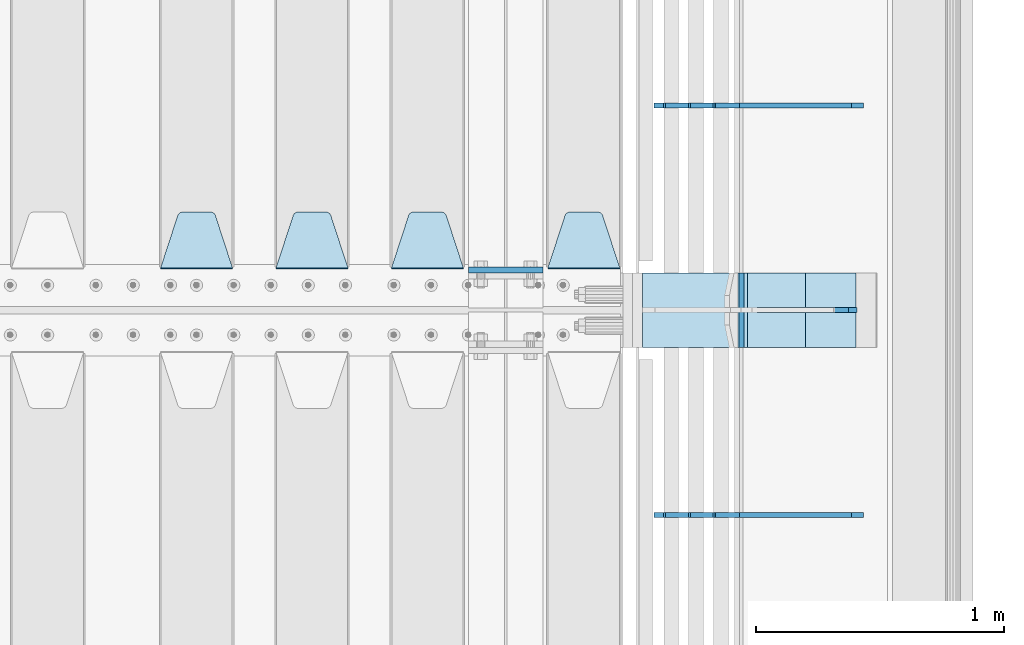
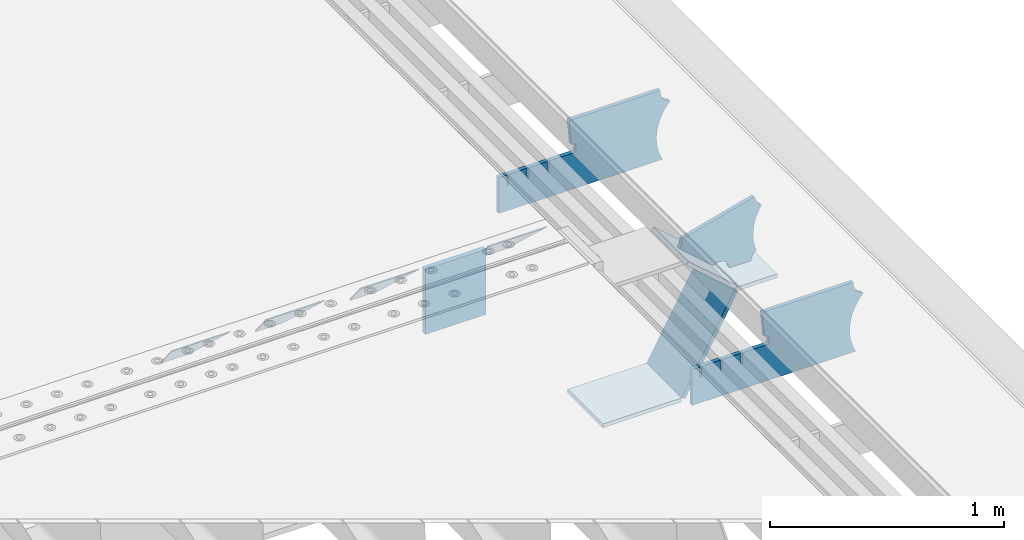
# One storey, part 226 of 247: 12 plates.
"""IFC2X3 building model written with IfcOpenShell, lengths in millimetres."""

from ifc_helpers import new_model, si_unit, frame, origin_with_axes, place, context, subcontext, project, spatial, faceted_brep, material, type_object, element, save


model = new_model("IFC2X3")

# Units and contexts
model_context = context("Model", 3, precision=1e-05, world=origin_with_axes())
body_context = subcontext(model_context, "Body", "Model", "MODEL_VIEW")
ifc_project = project(units=[si_unit("LENGTHUNIT", "METRE", prefix="MILLI"), si_unit("AREAUNIT", "SQUARE_METRE"), si_unit("VOLUMEUNIT", "CUBIC_METRE"), si_unit("MASSUNIT", "GRAM", prefix="KILO"), si_unit("TIMEUNIT", "SECOND"), si_unit("PLANEANGLEUNIT", "RADIAN"), si_unit("SOLIDANGLEUNIT", "STERADIAN"), si_unit("THERMODYNAMICTEMPERATUREUNIT", "DEGREE_CELSIUS"), si_unit("LUMINOUSINTENSITYUNIT", "LUMEN")], contexts=[model_context])

# Site, building, storey
site_placement = place(None, origin_with_axes())
site = spatial("IfcSite", under=ifc_project, at=site_placement, CompositionType="ELEMENT")
building_placement = place(site_placement, origin_with_axes())
building = spatial("IfcBuilding", under=site, at=building_placement, Name="Standard", CompositionType="ELEMENT")
storey_placement = place(building_placement, origin_with_axes())
storey = spatial("IfcBuildingStorey", under=building, at=storey_placement, Name="Undefined", CompositionType="ELEMENT", Elevation=0.0)

# Plates
ifc_material = material(Name="STEEL/S355N")
plate_type_1 = type_object("IfcPlateType", PredefinedType="NOTDEFINED")
plate_1_placement = place(storey_placement, frame((16195.0, 3162.5, -340.000000000044), z_axis=(0.0, 0.0, 1.0), x_axis=(1.0, 0.0, 0.0)))
element("IfcPlate", 1, at=plate_1_placement, inside=storey, type_object=plate_type_1, material=ifc_material, context=body_context, shape_type="Brep", body=[
    faceted_brep([(0.0, -12.5, 0.0), (0.0, -12.5, 340.0), (0.0, 12.5, 340.0), (0.0, 12.5, 0.0), (300.0, -12.5, 340.0), (300.0, 12.5, 340.0), (300.0, -12.5, 0.0), (300.0, 12.5, 0.0)], [[[0, 1, 2, 3]], [[1, 4, 5, 2]], [[4, 6, 7, 5]], [[6, 0, 3, 7]], [[5, 7, 3, 2]], [[6, 4, 1, 0]]]),
])
plate_type_2 = type_object("IfcPlateType", PredefinedType="NOTDEFINED")
plate_2_placement = place(storey_placement, frame((16805.0, 3168.23223304703, -1.76776695296758), z_axis=(0.0, 0.707106781186548, -0.707106781186547), x_axis=(-1.0, 0.0, 0.0)))
element("IfcPlate", 2, at=plate_2_placement, inside=storey, type_object=plate_type_2, material=ifc_material, context=body_context, shape_type="Brep", body=[
    faceted_brep([(0.0, -2.49999999999909, 0.0), (69.345504679477, -2.5, 300.17173142483), (69.345504679477, 2.50000000000091, 300.171731424831), (0.0, 2.5, -9.09494701772928e-13), (70.9274061199576, -2.5, 304.897442415399), (70.9274061199576, 2.50000000000091, 304.8974424154), (73.3818627772307, -2.49999999999909, 309.234538108527), (73.3818627772307, 2.5, 309.234538108526), (76.6187032999551, -2.5, 313.023683126102), (76.6187032999551, 2.50000000000091, 313.023683126102), (80.5190132704993, -2.49999999999909, 316.125672595371), (80.5190132704993, 2.50000000000091, 316.125672595372), (84.9395038596849, -2.49999999999909, 318.426546230476), (84.9395038596849, 2.5, 318.426546230475), (89.7177759439219, -2.5, 319.841774983274), (89.7177759439219, 2.50000000000091, 319.841774983275), (94.678286292652, -2.5, 320.319366455077), (94.678286292652, 2.50000000000091, 320.319366455077), (195.321713707348, -2.5, 320.319366455077), (195.321713707348, 2.50000000000091, 320.319366455077), (200.282224056078, -2.5, 319.841774983274), (200.282224056078, 2.50000000000091, 319.841774983275), (205.060496140315, -2.5, 318.426546230475), (205.060496140315, 2.5, 318.426546230474), (209.480986729501, -2.49999999999818, 316.12567259537), (209.480986729501, 2.50000000000091, 316.12567259537), (213.381296700045, -2.5, 313.023683126101), (213.381296700045, 2.50000000000091, 313.023683126101), (216.618137222769, -2.5, 309.234538108525), (216.618137222769, 2.5, 309.234538108525), (219.072593880042, -2.49999999999909, 304.897442415398), (219.072593880042, 2.5, 304.897442415398), (220.654495320523, -2.5, 300.17173142483), (220.654495320523, 2.50000000000091, 300.171731424831), (290.0, -2.49999999999909, 0.0), (290.0, 2.5, -9.09494701772928e-13)], [[[0, 1, 2, 3]], [[1, 4, 5, 2]], [[4, 6, 7, 5]], [[6, 8, 9, 7]], [[8, 10, 11, 9]], [[10, 12, 13, 11]], [[12, 14, 15, 13]], [[14, 16, 17, 15]], [[16, 18, 19, 17]], [[18, 20, 21, 19]], [[20, 22, 23, 21]], [[22, 24, 25, 23]], [[24, 26, 27, 25]], [[26, 28, 29, 27]], [[28, 30, 31, 29]], [[30, 32, 33, 31]], [[32, 34, 35, 33]], [[34, 0, 3, 35]], [[5, 7, 9, 11, 13, 15, 17, 19, 21, 23, 25, 27, 29, 31, 33, 35, 3, 2]], [[34, 32, 30, 28, 26, 24, 22, 20, 18, 16, 14, 12, 10, 8, 6, 4, 1, 0]]]),
])
plate_3_placement = place(storey_placement, frame((16175.0, 3168.23223304703, -1.76776695296758), z_axis=(0.0, 0.707106781186548, -0.707106781186547), x_axis=(-1.0, 0.0, 0.0)))
element("IfcPlate", 3, at=plate_3_placement, inside=storey, type_object=plate_type_2, material=ifc_material, context=body_context, shape_type="Brep", body=[
    faceted_brep([(0.0, -2.49999999999909, 0.0), (69.345504679477, -2.5, 300.17173142483), (69.345504679477, 2.50000000000091, 300.171731424831), (0.0, 2.5, -9.09494701772928e-13), (70.9274061199576, -2.5, 304.897442415399), (70.9274061199576, 2.50000000000091, 304.8974424154), (73.3818627772307, -2.49999999999909, 309.234538108527), (73.3818627772307, 2.5, 309.234538108526), (76.6187032999551, -2.5, 313.023683126102), (76.6187032999551, 2.50000000000091, 313.023683126102), (80.5190132704993, -2.49999999999909, 316.125672595371), (80.5190132704993, 2.50000000000091, 316.125672595372), (84.9395038596849, -2.49999999999909, 318.426546230476), (84.9395038596849, 2.5, 318.426546230475), (89.7177759439219, -2.5, 319.841774983274), (89.7177759439219, 2.50000000000091, 319.841774983275), (94.678286292652, -2.5, 320.319366455077), (94.678286292652, 2.50000000000091, 320.319366455077), (195.321713707348, -2.5, 320.319366455077), (195.321713707348, 2.50000000000091, 320.319366455077), (200.282224056078, -2.5, 319.841774983274), (200.282224056078, 2.50000000000091, 319.841774983275), (205.060496140315, -2.5, 318.426546230475), (205.060496140315, 2.5, 318.426546230474), (209.480986729501, -2.49999999999818, 316.12567259537), (209.480986729501, 2.50000000000091, 316.12567259537), (213.381296700045, -2.5, 313.023683126101), (213.381296700045, 2.50000000000091, 313.023683126101), (216.618137222769, -2.5, 309.234538108525), (216.618137222769, 2.5, 309.234538108525), (219.072593880042, -2.49999999999909, 304.897442415398), (219.072593880042, 2.5, 304.897442415398), (220.654495320523, -2.5, 300.17173142483), (220.654495320523, 2.50000000000091, 300.171731424831), (290.0, -2.49999999999909, 0.0), (290.0, 2.5, -9.09494701772928e-13)], [[[0, 1, 2, 3]], [[1, 4, 5, 2]], [[4, 6, 7, 5]], [[6, 8, 9, 7]], [[8, 10, 11, 9]], [[10, 12, 13, 11]], [[12, 14, 15, 13]], [[14, 16, 17, 15]], [[16, 18, 19, 17]], [[18, 20, 21, 19]], [[20, 22, 23, 21]], [[22, 24, 25, 23]], [[24, 26, 27, 25]], [[26, 28, 29, 27]], [[28, 30, 31, 29]], [[30, 32, 33, 31]], [[32, 34, 35, 33]], [[34, 0, 3, 35]], [[5, 7, 9, 11, 13, 15, 17, 19, 21, 23, 25, 27, 29, 31, 33, 35, 3, 2]], [[34, 32, 30, 28, 26, 24, 22, 20, 18, 16, 14, 12, 10, 8, 6, 4, 1, 0]]]),
])
plate_4_placement = place(storey_placement, frame((15710.0, 3168.23223304703, -1.76776695296758), z_axis=(0.0, 0.707106781186548, -0.707106781186547), x_axis=(-1.0, 0.0, 0.0)))
element("IfcPlate", 4, at=plate_4_placement, inside=storey, type_object=plate_type_2, material=ifc_material, context=body_context, shape_type="Brep", body=[
    faceted_brep([(0.0, -2.49999999999909, 0.0), (69.345504679477, -2.5, 300.17173142483), (69.345504679477, 2.50000000000091, 300.171731424831), (0.0, 2.5, -9.09494701772928e-13), (70.9274061199576, -2.5, 304.897442415399), (70.9274061199576, 2.50000000000091, 304.8974424154), (73.3818627772307, -2.49999999999909, 309.234538108527), (73.3818627772307, 2.5, 309.234538108526), (76.6187032999551, -2.5, 313.023683126102), (76.6187032999551, 2.50000000000091, 313.023683126102), (80.5190132704993, -2.49999999999909, 316.125672595371), (80.5190132704993, 2.50000000000091, 316.125672595372), (84.9395038596849, -2.49999999999909, 318.426546230476), (84.9395038596849, 2.5, 318.426546230475), (89.7177759439219, -2.5, 319.841774983274), (89.7177759439219, 2.50000000000091, 319.841774983275), (94.678286292652, -2.5, 320.319366455077), (94.678286292652, 2.50000000000091, 320.319366455077), (195.321713707348, -2.5, 320.319366455077), (195.321713707348, 2.50000000000091, 320.319366455077), (200.282224056078, -2.5, 319.841774983274), (200.282224056078, 2.50000000000091, 319.841774983275), (205.060496140315, -2.5, 318.426546230475), (205.060496140315, 2.5, 318.426546230474), (209.480986729501, -2.49999999999818, 316.12567259537), (209.480986729501, 2.50000000000091, 316.12567259537), (213.381296700045, -2.5, 313.023683126101), (213.381296700045, 2.50000000000091, 313.023683126101), (216.618137222769, -2.5, 309.234538108525), (216.618137222769, 2.5, 309.234538108525), (219.072593880042, -2.49999999999909, 304.897442415398), (219.072593880042, 2.5, 304.897442415398), (220.654495320523, -2.5, 300.17173142483), (220.654495320523, 2.50000000000091, 300.171731424831), (290.0, -2.49999999999909, 0.0), (290.0, 2.5, -9.09494701772928e-13)], [[[0, 1, 2, 3]], [[1, 4, 5, 2]], [[4, 6, 7, 5]], [[6, 8, 9, 7]], [[8, 10, 11, 9]], [[10, 12, 13, 11]], [[12, 14, 15, 13]], [[14, 16, 17, 15]], [[16, 18, 19, 17]], [[18, 20, 21, 19]], [[20, 22, 23, 21]], [[22, 24, 25, 23]], [[24, 26, 27, 25]], [[26, 28, 29, 27]], [[28, 30, 31, 29]], [[30, 32, 33, 31]], [[32, 34, 35, 33]], [[34, 0, 3, 35]], [[5, 7, 9, 11, 13, 15, 17, 19, 21, 23, 25, 27, 29, 31, 33, 35, 3, 2]], [[34, 32, 30, 28, 26, 24, 22, 20, 18, 16, 14, 12, 10, 8, 6, 4, 1, 0]]]),
])
plate_5_placement = place(storey_placement, frame((15245.0, 3168.23223304703, -1.76776695296758), z_axis=(0.0, 0.707106781186548, -0.707106781186547), x_axis=(-1.0, 0.0, 0.0)))
element("IfcPlate", 5, at=plate_5_placement, inside=storey, type_object=plate_type_2, material=ifc_material, context=body_context, shape_type="Brep", body=[
    faceted_brep([(0.0, -2.49999999999909, 0.0), (69.345504679477, -2.5, 300.17173142483), (69.345504679477, 2.50000000000091, 300.171731424831), (0.0, 2.5, -9.09494701772928e-13), (70.9274061199576, -2.5, 304.897442415399), (70.9274061199576, 2.50000000000091, 304.8974424154), (73.3818627772307, -2.49999999999909, 309.234538108527), (73.3818627772307, 2.5, 309.234538108526), (76.6187032999551, -2.5, 313.023683126102), (76.6187032999551, 2.50000000000091, 313.023683126102), (80.5190132704993, -2.49999999999909, 316.125672595371), (80.5190132704993, 2.50000000000091, 316.125672595372), (84.9395038596849, -2.49999999999909, 318.426546230476), (84.9395038596849, 2.5, 318.426546230475), (89.7177759439219, -2.5, 319.841774983274), (89.7177759439219, 2.50000000000091, 319.841774983275), (94.678286292652, -2.5, 320.319366455077), (94.678286292652, 2.50000000000091, 320.319366455077), (195.321713707348, -2.5, 320.319366455077), (195.321713707348, 2.50000000000091, 320.319366455077), (200.282224056078, -2.5, 319.841774983274), (200.282224056078, 2.50000000000091, 319.841774983275), (205.060496140315, -2.5, 318.426546230475), (205.060496140315, 2.5, 318.426546230474), (209.480986729501, -2.49999999999818, 316.12567259537), (209.480986729501, 2.50000000000091, 316.12567259537), (213.381296700045, -2.5, 313.023683126101), (213.381296700045, 2.50000000000091, 313.023683126101), (216.618137222769, -2.5, 309.234538108525), (216.618137222769, 2.5, 309.234538108525), (219.072593880042, -2.49999999999909, 304.897442415398), (219.072593880042, 2.5, 304.897442415398), (220.654495320523, -2.5, 300.17173142483), (220.654495320523, 2.50000000000091, 300.171731424831), (290.0, -2.49999999999909, 0.0), (290.0, 2.5, -9.09494701772928e-13)], [[[0, 1, 2, 3]], [[1, 4, 5, 2]], [[4, 6, 7, 5]], [[6, 8, 9, 7]], [[8, 10, 11, 9]], [[10, 12, 13, 11]], [[12, 14, 15, 13]], [[14, 16, 17, 15]], [[16, 18, 19, 17]], [[18, 20, 21, 19]], [[20, 22, 23, 21]], [[22, 24, 25, 23]], [[24, 26, 27, 25]], [[26, 28, 29, 27]], [[28, 30, 31, 29]], [[30, 32, 33, 31]], [[32, 34, 35, 33]], [[34, 0, 3, 35]], [[5, 7, 9, 11, 13, 15, 17, 19, 21, 23, 25, 27, 29, 31, 33, 35, 3, 2]], [[34, 32, 30, 28, 26, 24, 22, 20, 18, 16, 14, 12, 10, 8, 6, 4, 1, 0]]]),
])
plate_type_3 = type_object("IfcPlateType", PredefinedType="NOTDEFINED")
plate_6_placement = place(storey_placement, frame((17840.9988502513, 2999.99999999933, -28.9999913318487), z_axis=(0.260769276985653, 0.0, -0.965401151946889), x_axis=(-0.965401151946889, 0.0, -0.260769276985654)))
element("IfcPlate", 6, at=plate_6_placement, inside=storey, type_object=plate_type_3, material=ifc_material, context=body_context, shape_type="Brep", body=[
    faceted_brep([(183.436474692331, 10.0, 275.852500330424), (184.918388609061, 10.0, 264.417843531322), (184.918388609061, -10.0, 264.417843531322), (183.436474692331, -10.0, 275.852500330424), (183.794583267612, 10.0, 224.576469334607), (183.794583267612, -10.0, 224.576469334607), (176.452049775839, 10.0, 185.401410454621), (176.452049775839, -10.0, 185.401410454621), (163.071585676767, 10.0, 147.857286855558), (163.071585676767, -10.0, 147.857286855558), (143.982662403749, 10.0, 112.868559462227), (143.982662403749, -10.0, 112.868559462227), (119.655312600251, 10.0, 81.2967668639831), (119.655312600251, -10.0, 81.2967668639831), (100.960891712752, 10.0, 63.6280409830933), (100.960891712752, -10.0, 63.6280409830933), (194.486836975902, -10.0, 278.751956446687), (207.178624553377, -10.0, 286.650994937514), (207.178624553377, 10.0, 286.650994937514), (194.486836975902, 10.0, 278.751956446687), (216.968013469446, -10.0, 297.948965801394), (216.968013469446, 10.0, 297.948965801394), (222.979925232863, -10.0, 311.635937633766), (222.979925232863, 10.0, 311.635937633766), (323.381647032762, -10.0, 284.515917834983), (323.381647032762, 10.0, 284.515917834983), (321.720617177336, -10.0, 268.853198956859), (321.720617177336, 10.0, 268.853198956859), (325.01434448114, -10.0, 253.450889283181), (325.01434448114, 10.0, 253.450889283181), (332.935986082481, -10.0, 239.837389469553), (332.935986082481, 10.0, 239.837389469553), (344.699462330093, -10.0, 229.363593146935), (344.699462330093, 10.0, 229.363593146935), (359.137460970807, -10.0, 223.0688351622), (359.137460970807, 10.0, 223.0688351622), (374.817271777687, -10.0, 221.57775639289), (374.817271777687, 10.0, 221.57775639289), (390.182952880859, -10.0, 225.038330078124), (390.182952880859, 10.0, 225.038330078124), (512.90906051303, -10.0, 41.5599003357011), (512.90906051303, 10.0, 41.5599003357011), (503.648024844581, -10.0, 33.5643666747665), (503.648024844581, 10.0, 33.5643666747665), (496.606064569703, -10.0, 23.5590612989981), (496.606064569703, 10.0, 23.5590612989981), (492.204839143935, -10.0, 12.1430832451069), (492.204839143935, 10.0, 12.1430832451069), (490.707885742188, -10.0, 3.79259290639311e-10), (490.707885742188, 10.0, 3.79259290639311e-10), (120.0, -10.0, 9.18589648790658e-11), (120.0, 10.0, 9.18589648790658e-11), (117.226254779114, -10.0, 25.6516118492136), (117.226254779114, 10.0, 25.6516118492136), (109.03324682566, -10.0, 50.1173731020972), (109.03324682566, 10.0, 50.1173731020972)], [[[0, 1, 2, 3]], [[4, 5, 2, 1]], [[6, 7, 5, 4]], [[8, 9, 7, 6]], [[10, 11, 9, 8]], [[12, 13, 11, 10]], [[14, 15, 13, 12]], [[16, 17, 18, 19]], [[17, 20, 21, 18]], [[20, 22, 23, 21]], [[22, 24, 25, 23]], [[24, 26, 27, 25]], [[26, 28, 29, 27]], [[28, 30, 31, 29]], [[30, 32, 33, 31]], [[32, 34, 35, 33]], [[34, 36, 37, 35]], [[36, 38, 39, 37]], [[38, 40, 41, 39]], [[40, 42, 43, 41]], [[42, 44, 45, 43]], [[44, 46, 47, 45]], [[46, 48, 49, 47]], [[48, 50, 51, 49]], [[50, 52, 53, 51]], [[52, 54, 55, 53]], [[10, 8, 6, 4, 1, 0, 19, 18, 21, 23, 25, 27, 29, 31, 33, 35, 37, 39, 41, 43, 45, 47, 49, 51, 53, 55, 14, 12]], [[16, 19, 0, 3]], [[54, 52, 50, 48, 46, 44, 42, 40, 38, 36, 34, 32, 30, 28, 26, 24, 22, 20, 17, 16, 3, 2, 5, 7, 9, 11, 13, 15]], [[55, 54, 15, 14]]]),
])
plate_type_4 = type_object("IfcPlateType", PredefinedType="NOTDEFINED")
plate_7_placement = place(storey_placement, frame((17312.2260590443, 3149.99999999933, -177.219372761326), z_axis=(0.752414935148685, 0.0, -0.658689430130164), x_axis=(0.0, -0.999999999999548, -9.5100000000016e-07)))
element("IfcPlate", 7, at=plate_7_placement, inside=storey, type_object=plate_type_4, material=ifc_material, context=body_context, shape_type="Brep", body=[
    faceted_brep([(-5.6843418860808e-14, -9.99999999999989, 3.5527136788005e-15), (1.09139364212751e-10, -10.0000000000018, 320.0), (1.09139364212751e-10, 9.99999999999818, 319.999999999998), (-5.6843418860808e-14, 10.0000000000001, 3.5527136788005e-15), (300.0, -10.0000000000018, 320.0), (300.0, 9.99999999999818, 319.999999999998), (300.0, -10.0, 6.54836185276508e-11), (300.0, 9.99999999999818, 6.54836185276508e-11)], [[[0, 1, 2, 3]], [[1, 4, 5, 2]], [[4, 6, 7, 5]], [[6, 0, 3, 7]], [[5, 7, 3, 2]], [[6, 4, 1, 0]]]),
])
plate_8_placement = place(storey_placement, frame((17553.0007288109, 3150.00000000007, -408.004820491625), z_axis=(-0.484064236150485, 0.0, -0.875032465272031), x_axis=(0.0, -0.999999999999548, -9.5100000000016e-07)))
element("IfcPlate", 8, at=plate_8_placement, inside=storey, type_object=plate_type_4, material=ifc_material, context=body_context, shape_type="Brep", body=[
    faceted_brep([(-5.6843418860808e-14, -9.99999999999989, 3.5527136788005e-15), (3.86515239370056e-07, -10.0, 533.528442382813), (3.86515239370056e-07, 9.99999999999818, 533.528442382813), (-5.6843418860808e-14, 10.0000000000001, 3.5527136788005e-15), (300.003295898438, -10.0, 533.549133300782), (300.003295898438, 9.99999999999818, 533.549133300781), (300.0, -10.0, 6.54836185276508e-11), (300.0, 9.99999999999818, 6.54836185276508e-11)], [[[0, 1, 2, 3]], [[1, 4, 5, 2]], [[4, 6, 7, 5]], [[6, 0, 3, 7]], [[5, 7, 3, 2]], [[6, 4, 1, 0]]]),
])
plate_9_placement = place(storey_placement, frame((16896.9988298914, 3150.00000000007, -879.999999999866), z_axis=(0.0, -0.999999999999548, -9.5100000000016e-07), x_axis=(1.0, 0.0, 0.0)))
element("IfcPlate", 9, at=plate_9_placement, inside=storey, type_object=plate_type_4, material=ifc_material, context=body_context, shape_type="Brep", body=[
    faceted_brep([(-5.6843418860808e-14, -9.99999999999989, 3.5527136788005e-15), (-1.98724592337385e-10, -10.0000000000036, 300.0), (-1.98724592337385e-10, 10.0, 300.0), (-5.6843418860808e-14, 10.0000000000001, 3.5527136788005e-15), (389.0, -10.0, 300.0), (389.0, 10.0, 300.0), (389.0, -10.0, 0.0), (389.0, 10.0, 0.0)], [[[0, 1, 2, 3]], [[1, 4, 5, 2]], [[4, 6, 7, 5]], [[6, 0, 3, 7]], [[5, 7, 3, 2]], [[6, 4, 1, 0]]]),
])
plate_type_5 = type_object("IfcPlateType", PredefinedType="NOTDEFINED")
plate_10_placement = place(storey_placement, frame((17756.9988298914, 3149.99999999933, -397.999999999763), z_axis=(-1.0, 0.0, 0.0), x_axis=(0.0, -0.999999999999548, -9.5100000000016e-07)))
element("IfcPlate", 10, at=plate_10_placement, inside=storey, type_object=plate_type_5, material=ifc_material, context=body_context, shape_type="Brep", body=[
    faceted_brep([(-5.6843418860808e-14, -9.99999999999989, 3.5527136788005e-15), (4.63842297904193e-10, -10.0, 204.0), (4.63842297904193e-10, 10.0, 204.0), (-5.6843418860808e-14, 10.0000000000001, 3.5527136788005e-15), (300.0, -10.0, 204.0), (300.0, 10.0, 204.0), (300.0, -10.0, 6.54836185276508e-11), (300.0, 9.99999999999818, 6.54836185276508e-11)], [[[0, 1, 2, 3]], [[1, 4, 5, 2]], [[4, 6, 7, 5]], [[6, 0, 3, 7]], [[5, 7, 3, 2]], [[6, 4, 1, 0]]]),
])
plate_type_6 = type_object("IfcPlateType", PredefinedType="NOTDEFINED")
plate_11_placement = place(storey_placement, frame((17782.9182339676, 2174.99928283691, -374.002067436517), z_axis=(0.0, 0.0, 1.0), x_axis=(-1.0, 0.0, 0.0)))
element("IfcPlate", 11, at=plate_11_placement, inside=storey, type_object=plate_type_6, material=ifc_material, context=body_context, shape_type="Brep", body=[
    faceted_brep([(801.919404066546, -10.0, 188.0), (801.919404066546, 10.0, 188.0), (801.919404066546, 10.0, 132.002067436952), (801.919404066546, -10.0, 132.002067436952), (793.919404066546, 10.0, 132.002067436952), (793.919404066546, -10.0, 132.002067436952), (793.919404066546, 10.0, 180.002067436952), (793.919404066546, -10.0, 180.002067436952), (793.527856196906, 10.0, 182.474203391951), (793.527856196906, -10.0, 182.474203391951), (792.391540021545, 10.0, 184.704349455291), (792.391540021545, -10.0, 184.704349455291), (790.621686084887, 10.0, 186.474203391951), (790.621686084887, -10.0, 186.474203391951), (788.391540021545, 10.0, 187.610519567313), (788.391540021545, -10.0, 187.610519567313), (785.919404066546, -10.0, 188.002067436952), (785.919404066546, 10.0, 188.0), (841.0, -10.0, 188.0), (841.0, -10.0, 0.0), (841.0, 10.0, 0.0), (841.0, 10.0, 188.0), (33.3619566736015, -10.0, 0.0), (33.3619566736015, 10.0, 0.0), (36.2350612208174, -10.0, 4.68848050267013), (36.2350612208174, 10.0, 4.68848050267013), (51.4877592159428, -10.0, 41.5117508652784), (51.4877592159428, 10.0, 41.5117508652784), (60.792242588137, -10.0, 80.2677133162964), (60.792242588137, 10.0, 80.2677133162964), (63.9194040769726, -10.0, 120.002067436515), (63.9194040769726, 10.0, 120.002067436515), (60.792242588137, -10.0, 159.736421556734), (60.792242588137, 10.0, 159.736421556734), (51.4877592159428, -10.0, 198.492384007752), (51.4877592159428, 10.0, 198.492384007752), (36.2350612208174, -10.0, 235.31565437036), (36.2350612208174, 10.0, 235.31565437036), (15.4097206482074, -10.0, 269.299521518803), (15.4097206482074, 10.0, 269.299521518803), (-3.35474438098754, -10.0, 291.269887256574), (-3.35474438098754, 10.0, 291.269887256574), (-2.36881039375294, -10.0, 291.426043859339), (-2.36881039375294, 10.0, 291.426043859339), (17.1449676604716, -10.0, 301.368810393754), (17.1449676604716, 10.0, 301.368810393754), (32.6311896062471, -10.0, 316.855032339527), (32.6311896062471, 10.0, 316.855032339527), (42.573956140659, -10.0, 336.368810393754), (42.573956140659, 10.0, 336.368810393754), (46.0, -10.0, 358.0), (46.0, 10.0, 358.0), (45.0495205499137, -10.0, 364.001091067617), (45.0495205499137, 10.0, 364.001091067617), (495.040008544922, -10.0, 364.010009765625), (495.040008544922, 10.0, 364.010009765625), (483.600036621094, -10.0, 233.759994506836), (483.600036621094, 10.0, 233.759994506836), (472.0, -10.0, 233.759994506836), (472.0, 10.0, 233.759994506836), (468.909830056251, -10.0, 233.270559669787), (468.909830056251, 10.0, 233.270559669787), (466.122147477075, -10.0, 231.850164450585), (466.122147477075, 10.0, 231.850164450585), (463.909830056251, -10.0, 229.637847029761), (463.909830056251, 10.0, 229.637847029761), (462.489434837047, -10.0, 226.850164450585), (462.489434837047, 10.0, 226.850164450585), (462.0, -10.0, 223.759994506836), (462.0, 10.0, 223.759994506836), (462.0, -10.0, 198.0), (462.0, 10.0, 198.0), (462.489434837047, -10.0, 194.909830056251), (462.489434837047, 10.0, 194.909830056251), (463.909830056251, -10.0, 192.122147477075), (463.909830056251, 10.0, 192.122147477075), (466.122147477075, -10.0, 189.909830056251), (466.122147477075, 10.0, 189.909830056251), (468.909830056251, -10.0, 188.489434837048), (468.909830056251, 10.0, 188.489434837048), (472.0, -10.0, 188.0), (472.0, 10.0, 188.0), (585.919404066546, -10.0, 188.002067436952), (585.919404066546, 10.0, 188.0), (588.391540021545, -10.0, 187.610519567313), (588.391540021545, 10.0, 187.610519567313), (590.621686084887, -10.0, 186.474203391951), (590.621686084887, 10.0, 186.474203391951), (592.391540021545, -10.0, 184.704349455291), (592.391540021545, 10.0, 184.704349455291), (593.527856196906, -10.0, 182.474203391951), (593.527856196906, 10.0, 182.474203391951), (593.919404066546, -10.0, 180.002067436952), (593.919404066546, 10.0, 180.002067436952), (593.919404066546, -10.0, 132.002067436952), (593.919404066546, 10.0, 132.002067436952), (601.919404066546, -10.0, 132.002067436952), (601.919404066546, 10.0, 132.002067436952), (601.919404066546, -10.0, 188.0), (601.919404066546, 10.0, 188.0), (685.919404066546, -10.0, 188.002067436952), (685.919404066546, 10.0, 188.0), (688.391540021545, -10.0, 187.610519567313), (688.391540021545, 10.0, 187.610519567313), (690.621686084887, -10.0, 186.474203391951), (690.621686084887, 10.0, 186.474203391951), (692.391540021545, -10.0, 184.704349455291), (692.391540021545, 10.0, 184.704349455291), (693.527856196906, -10.0, 182.474203391951), (693.527856196906, 10.0, 182.474203391951), (693.919404066546, -10.0, 180.002067436952), (693.919404066546, 10.0, 180.002067436952), (693.919404066546, -10.0, 132.002067436952), (693.919404066546, 10.0, 132.002067436952), (701.919404066546, -10.0, 132.002067436952), (701.919404066546, 10.0, 132.002067436952), (701.919404066546, -10.0, 188.0), (701.919404066546, 10.0, 188.0)], [[[0, 1, 2, 3]], [[3, 2, 4, 5]], [[5, 4, 6, 7]], [[7, 6, 8, 9]], [[9, 8, 10, 11]], [[11, 10, 12, 13]], [[13, 12, 14, 15]], [[16, 15, 14, 17]], [[18, 19, 20, 21]], [[20, 19, 22, 23]], [[22, 24, 25, 23]], [[26, 27, 25, 24]], [[28, 29, 27, 26]], [[30, 31, 29, 28]], [[32, 33, 31, 30]], [[34, 35, 33, 32]], [[36, 37, 35, 34]], [[38, 39, 37, 36]], [[39, 38, 40, 41]], [[40, 42, 43, 41]], [[44, 45, 43, 42]], [[46, 47, 45, 44]], [[48, 49, 47, 46]], [[50, 51, 49, 48]], [[52, 53, 51, 50]], [[54, 55, 53, 52]], [[54, 56, 57, 55]], [[56, 58, 59, 57]], [[58, 60, 61, 59]], [[60, 62, 63, 61]], [[62, 64, 65, 63]], [[64, 66, 67, 65]], [[66, 68, 69, 67]], [[68, 70, 71, 69]], [[70, 72, 73, 71]], [[72, 74, 75, 73]], [[74, 76, 77, 75]], [[76, 78, 79, 77]], [[78, 80, 81, 79]], [[81, 80, 82, 83]], [[82, 84, 85, 83]], [[86, 87, 85, 84]], [[88, 89, 87, 86]], [[90, 91, 89, 88]], [[92, 93, 91, 90]], [[94, 95, 93, 92]], [[96, 97, 95, 94]], [[98, 99, 97, 96]], [[99, 98, 100, 101]], [[100, 102, 103, 101]], [[104, 105, 103, 102]], [[106, 107, 105, 104]], [[108, 109, 107, 106]], [[110, 111, 109, 108]], [[112, 113, 111, 110]], [[114, 115, 113, 112]], [[116, 117, 115, 114]], [[117, 116, 16, 17]], [[12, 10, 8, 6, 4, 2, 1, 21, 20, 23, 25, 27, 29, 31, 33, 35, 37, 39, 41, 43, 45, 47, 49, 51, 53, 55, 57, 59, 61, 63, 65, 67, 69, 71, 73, 75, 77, 79, 81, 83, 85, 87, 89, 91, 93, 95, 97, 99, 101, 103, 105, 107, 109, 111, 113, 115, 117, 17, 14]], [[18, 21, 1, 0]], [[116, 114, 112, 110, 108, 106, 104, 102, 100, 98, 96, 94, 92, 90, 88, 86, 84, 82, 80, 78, 76, 74, 72, 70, 68, 66, 64, 62, 60, 58, 56, 54, 52, 50, 48, 46, 44, 42, 40, 38, 36, 34, 32, 30, 28, 26, 24, 22, 19, 18, 0, 3, 5, 7, 9, 11, 13, 15, 16]]]),
])
plate_12_placement = place(storey_placement, frame((17782.9182339676, 3824.99928283691, -374.002067436517), z_axis=(0.0, 0.0, 1.0), x_axis=(-1.0, 0.0, 0.0)))
element("IfcPlate", 12, at=plate_12_placement, inside=storey, type_object=plate_type_6, material=ifc_material, context=body_context, shape_type="Brep", body=[
    faceted_brep([(801.919404066546, -10.0, 188.0), (801.919404066546, 10.0, 188.0), (801.919404066546, 10.0, 132.002067436952), (801.919404066546, -10.0, 132.002067436952), (793.919404066546, 10.0, 132.002067436952), (793.919404066546, -10.0, 132.002067436952), (793.919404066546, 10.0, 180.002067436952), (793.919404066546, -10.0, 180.002067436952), (793.527856196906, 10.0, 182.474203391951), (793.527856196906, -10.0, 182.474203391951), (792.391540021545, 10.0, 184.704349455291), (792.391540021545, -10.0, 184.704349455291), (790.621686084887, 10.0, 186.474203391951), (790.621686084887, -10.0, 186.474203391951), (788.391540021545, 10.0, 187.610519567313), (788.391540021545, -10.0, 187.610519567313), (785.919404066546, -10.0, 188.002067436952), (785.919404066546, 10.0, 188.0), (841.0, -10.0, 188.0), (841.0, -10.0, 0.0), (841.0, 10.0, 0.0), (841.0, 10.0, 188.0), (33.3619566736015, -10.0, 0.0), (33.3619566736015, 10.0, 0.0), (36.2350612208174, -10.0, 4.68848050267013), (36.2350612208174, 10.0, 4.68848050267013), (51.4877592159428, -10.0, 41.5117508652784), (51.4877592159428, 10.0, 41.5117508652784), (60.792242588137, -10.0, 80.2677133162964), (60.792242588137, 10.0, 80.2677133162964), (63.9194040769726, -10.0, 120.002067436515), (63.9194040769726, 10.0, 120.002067436515), (60.792242588137, -10.0, 159.736421556734), (60.792242588137, 10.0, 159.736421556734), (51.4877592159428, -10.0, 198.492384007752), (51.4877592159428, 10.0, 198.492384007752), (36.2350612208174, -10.0, 235.31565437036), (36.2350612208174, 10.0, 235.31565437036), (15.4097206482074, -10.0, 269.299521518803), (15.4097206482074, 10.0, 269.299521518803), (-3.35474438098754, -10.0, 291.269887256574), (-3.35474438098754, 10.0, 291.269887256574), (-2.36881039375294, -10.0, 291.426043859339), (-2.36881039375294, 10.0, 291.426043859339), (17.1449676604716, -10.0, 301.368810393754), (17.1449676604716, 10.0, 301.368810393754), (32.6311896062471, -10.0, 316.855032339527), (32.6311896062471, 10.0, 316.855032339527), (42.573956140659, -10.0, 336.368810393754), (42.573956140659, 10.0, 336.368810393754), (46.0, -10.0, 358.0), (46.0, 10.0, 358.0), (45.0495205499137, -10.0, 364.001091067617), (45.0495205499137, 10.0, 364.001091067617), (495.040008544922, -10.0, 364.010009765625), (495.040008544922, 10.0, 364.010009765625), (483.600036621094, -10.0, 233.759994506836), (483.600036621094, 10.0, 233.759994506836), (472.0, -10.0, 233.759994506836), (472.0, 10.0, 233.759994506836), (468.909830056251, -10.0, 233.270559669787), (468.909830056251, 10.0, 233.270559669787), (466.122147477075, -10.0, 231.850164450585), (466.122147477075, 10.0, 231.850164450585), (463.909830056251, -10.0, 229.637847029761), (463.909830056251, 10.0, 229.637847029761), (462.489434837047, -10.0, 226.850164450585), (462.489434837047, 10.0, 226.850164450585), (462.0, -10.0, 223.759994506836), (462.0, 10.0, 223.759994506836), (462.0, -10.0, 198.0), (462.0, 10.0, 198.0), (462.489434837047, -10.0, 194.909830056251), (462.489434837047, 10.0, 194.909830056251), (463.909830056251, -10.0, 192.122147477075), (463.909830056251, 10.0, 192.122147477075), (466.122147477075, -10.0, 189.909830056251), (466.122147477075, 10.0, 189.909830056251), (468.909830056251, -10.0, 188.489434837048), (468.909830056251, 10.0, 188.489434837048), (472.0, -10.0, 188.0), (472.0, 10.0, 188.0), (585.919404066546, -10.0, 188.002067436952), (585.919404066546, 10.0, 188.0), (588.391540021545, -10.0, 187.610519567313), (588.391540021545, 10.0, 187.610519567313), (590.621686084887, -10.0, 186.474203391951), (590.621686084887, 10.0, 186.474203391951), (592.391540021545, -10.0, 184.704349455291), (592.391540021545, 10.0, 184.704349455291), (593.527856196906, -10.0, 182.474203391951), (593.527856196906, 10.0, 182.474203391951), (593.919404066546, -10.0, 180.002067436952), (593.919404066546, 10.0, 180.002067436952), (593.919404066546, -10.0, 132.002067436952), (593.919404066546, 10.0, 132.002067436952), (601.919404066546, -10.0, 132.002067436952), (601.919404066546, 10.0, 132.002067436952), (601.919404066546, -10.0, 188.0), (601.919404066546, 10.0, 188.0), (685.919404066546, -10.0, 188.002067436952), (685.919404066546, 10.0, 188.0), (688.391540021545, -10.0, 187.610519567313), (688.391540021545, 10.0, 187.610519567313), (690.621686084887, -10.0, 186.474203391951), (690.621686084887, 10.0, 186.474203391951), (692.391540021545, -10.0, 184.704349455291), (692.391540021545, 10.0, 184.704349455291), (693.527856196906, -10.0, 182.474203391951), (693.527856196906, 10.0, 182.474203391951), (693.919404066546, -10.0, 180.002067436952), (693.919404066546, 10.0, 180.002067436952), (693.919404066546, -10.0, 132.002067436952), (693.919404066546, 10.0, 132.002067436952), (701.919404066546, -10.0, 132.002067436952), (701.919404066546, 10.0, 132.002067436952), (701.919404066546, -10.0, 188.0), (701.919404066546, 10.0, 188.0)], [[[0, 1, 2, 3]], [[3, 2, 4, 5]], [[5, 4, 6, 7]], [[7, 6, 8, 9]], [[9, 8, 10, 11]], [[11, 10, 12, 13]], [[13, 12, 14, 15]], [[16, 15, 14, 17]], [[18, 19, 20, 21]], [[20, 19, 22, 23]], [[22, 24, 25, 23]], [[26, 27, 25, 24]], [[28, 29, 27, 26]], [[30, 31, 29, 28]], [[32, 33, 31, 30]], [[34, 35, 33, 32]], [[36, 37, 35, 34]], [[38, 39, 37, 36]], [[39, 38, 40, 41]], [[40, 42, 43, 41]], [[44, 45, 43, 42]], [[46, 47, 45, 44]], [[48, 49, 47, 46]], [[50, 51, 49, 48]], [[52, 53, 51, 50]], [[54, 55, 53, 52]], [[54, 56, 57, 55]], [[56, 58, 59, 57]], [[58, 60, 61, 59]], [[60, 62, 63, 61]], [[62, 64, 65, 63]], [[64, 66, 67, 65]], [[66, 68, 69, 67]], [[68, 70, 71, 69]], [[70, 72, 73, 71]], [[72, 74, 75, 73]], [[74, 76, 77, 75]], [[76, 78, 79, 77]], [[78, 80, 81, 79]], [[81, 80, 82, 83]], [[82, 84, 85, 83]], [[86, 87, 85, 84]], [[88, 89, 87, 86]], [[90, 91, 89, 88]], [[92, 93, 91, 90]], [[94, 95, 93, 92]], [[96, 97, 95, 94]], [[98, 99, 97, 96]], [[99, 98, 100, 101]], [[100, 102, 103, 101]], [[104, 105, 103, 102]], [[106, 107, 105, 104]], [[108, 109, 107, 106]], [[110, 111, 109, 108]], [[112, 113, 111, 110]], [[114, 115, 113, 112]], [[116, 117, 115, 114]], [[117, 116, 16, 17]], [[12, 10, 8, 6, 4, 2, 1, 21, 20, 23, 25, 27, 29, 31, 33, 35, 37, 39, 41, 43, 45, 47, 49, 51, 53, 55, 57, 59, 61, 63, 65, 67, 69, 71, 73, 75, 77, 79, 81, 83, 85, 87, 89, 91, 93, 95, 97, 99, 101, 103, 105, 107, 109, 111, 113, 115, 117, 17, 14]], [[18, 21, 1, 0]], [[116, 114, 112, 110, 108, 106, 104, 102, 100, 98, 96, 94, 92, 90, 88, 86, 84, 82, 80, 78, 76, 74, 72, 70, 68, 66, 64, 62, 60, 58, 56, 54, 52, 50, 48, 46, 44, 42, 40, 38, 36, 34, 32, 30, 28, 26, 24, 22, 19, 18, 0, 3, 5, 7, 9, 11, 13, 15, 16]]]),
])

save(model, "model.ifc")
